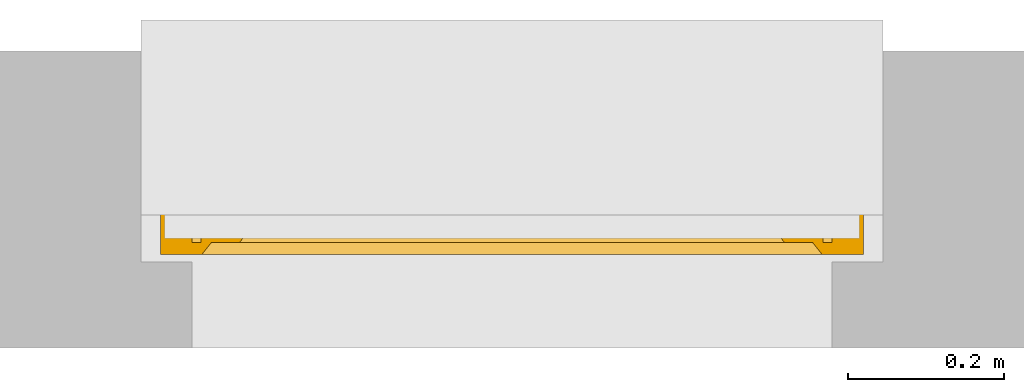
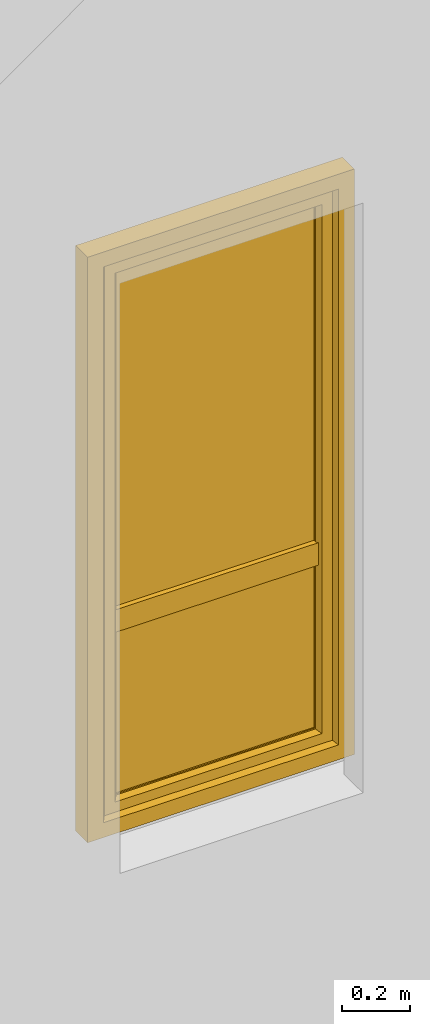
# One storey, part 2 of 3: 1 window.
"""IFC2X3 building model written with IfcOpenShell, lengths in millimetres."""

from ifc_helpers import new_model, entity, si_unit, converted_unit, derived_unit, direction, frame, origin, place, context, subcontext, project, spatial, faceted_brep, source, transform, mapped, material, material_list, type_object, type_shapes, element, save


model = new_model("IFC2X3")

# Units and contexts
model_context = context("Model", 3, precision=0.01, world=origin(), true_north=direction((6.12303176911189e-17, 1.0)))
context_of_model = context(None, 3, precision=0.01, world=origin(), true_north=direction((6.12303176911189e-17, 1.0)))
body_context = subcontext(model_context, "Body", "Model", "MODEL_VIEW")
ifc_project = project(units=[si_unit("LENGTHUNIT", "METRE", prefix="MILLI"), si_unit("AREAUNIT", "SQUARE_METRE"), si_unit("VOLUMEUNIT", "CUBIC_METRE"), converted_unit("PLANEANGLEUNIT", "DEGREE", entity("IfcRatioMeasure", 0.0174532925199433), si_unit("PLANEANGLEUNIT", "RADIAN"), dimensions=[0, 0, 0, 0, 0, 0, 0]), si_unit("MASSUNIT", "GRAM", prefix="KILO"), si_unit("TIMEUNIT", "SECOND"), si_unit("FREQUENCYUNIT", "HERTZ"), si_unit("THERMODYNAMICTEMPERATUREUNIT", "DEGREE_CELSIUS"), derived_unit("THERMALTRANSMITTANCEUNIT", [(si_unit("MASSUNIT", "GRAM", prefix="KILO"), 1), (si_unit("THERMODYNAMICTEMPERATUREUNIT", "KELVIN"), -1), (si_unit("TIMEUNIT", "SECOND"), -3)]), derived_unit("VOLUMETRICFLOWRATEUNIT", [(si_unit("LENGTHUNIT", "METRE"), 3), (si_unit("TIMEUNIT", "SECOND"), -1)]), si_unit("ELECTRICCURRENTUNIT", "AMPERE"), si_unit("ELECTRICVOLTAGEUNIT", "VOLT"), si_unit("POWERUNIT", "WATT"), si_unit("FORCEUNIT", "NEWTON", prefix="KILO"), si_unit("ILLUMINANCEUNIT", "LUX"), si_unit("LUMINOUSFLUXUNIT", "LUMEN"), si_unit("LUMINOUSINTENSITYUNIT", "CANDELA"), si_unit("PRESSUREUNIT", "PASCAL")], contexts=[model_context, context_of_model])

# Site, building, storey
site_placement = place(None, origin())
site = spatial("IfcSite", under=ifc_project, at=site_placement, CompositionType="ELEMENT")
building_placement = place(site_placement, origin())
building = spatial("IfcBuilding", under=site, at=building_placement, CompositionType="ELEMENT")
storey_placement = place(building_placement, origin())
storey = spatial("IfcBuildingStorey", under=building, at=storey_placement, CompositionType="ELEMENT", Elevation=0.0)

# Window
ifc_material_1 = material()
ifc_material_2 = material()
ifc_material_3 = material(Name="Rubber, Black")
ifc_material_4 = material()
ifc_material_5 = material()
ifc_material_list_1 = material_list([ifc_material_1, ifc_material_2, ifc_material_3, ifc_material_4, ifc_material_5])
ifc_material_list_2 = material_list([ifc_material_1, ifc_material_2, ifc_material_3, ifc_material_4, ifc_material_5])
window_style = type_object("IfcWindowStyle", ConstructionType="NOTDEFINED", OperationType="NOTDEFINED", ParameterTakesPrecedence=False, Sizeable=False, material=ifc_material_list_2)
shared_shape = source(origin(), body_context, "Body", "Brep", [
    faceted_brep([(-363.0, -95.0, 1063.0), (-363.0, -95.0, 1027.0), (-363.0, -87.0, 1027.0), (-363.0, -87.0, 1063.0), (-363.843235975199, -87.0, 1067.78534851355), (-363.422218385848, -95.0, 1065.39432433825), (-368.138446626751, -95.0, 1073.56228263264), (-369.997972538787, -87.0, 1075.12318487168), (-370.001013804009, -95.0, 1075.12494091651), (-385.861553373234, -87.0, 1073.56228263264), (-384.002027461198, -95.0, 1075.12318487169), (-383.998986195975, -87.0, 1075.12494091651), (-366.273622272693, -87.0, 1071.99693396951), (-366.275879449492, -95.0, 1071.99962434876), (-365.060158110598, -95.0, 1069.89413651262), (-374.567004156991, -87.0, 1076.78696961731), (-374.570462631182, -95.0, 1076.78757948931), (-372.285738217596, -95.0, 1075.95626020291), (-368.13579740574, -87.0, 1073.5600594206), (-363.844436771704, -95.0, 1067.78864867647), (-365.058429123946, -87.0, 1069.89114124153), (-372.282488347889, -87.0, 1075.9550772445), (-379.429537368803, -87.0, 1076.78757948931), (-379.432995842994, -95.0, 1076.78696961731), (-377.001729237088, -95.0, 1076.78727455331), (-381.717511652096, -95.0, 1075.9550772445), (-381.714261782389, -87.0, 1075.95626020291), (-388.941570876039, -95.0, 1069.89114124153), (-390.155563228281, -87.0, 1067.78864867647), (-390.156764024786, -95.0, 1067.78534851355), (-387.724120550493, -87.0, 1071.99962434876), (-387.726377727292, -95.0, 1071.99693396951), (-385.864202594245, -95.0, 1073.5600594206), (-376.998270762897, -87.0, 1076.78727455331), (-391.0, -95.0, 1063.0), (-390.577781614137, -87.0, 1065.39432433825), (-391.0, -87.0, 1063.0), (-388.939841889387, -87.0, 1069.89413651262), (-391.0, -95.0, 1027.0), (-391.0, -87.0, 1027.0), (-390.156764024786, -95.0, 1022.21465148647), (-390.156764024786, -87.0, 1022.21465148647), (-384.002027461198, -95.0, 1014.87681512833), (-385.864202594245, -95.0, 1016.43994057942), (-387.726377727292, -95.0, 1018.00306603051), (-387.726377727292, -87.0, 1018.00306603051), (-385.864202594245, -87.0, 1016.43994057942), (-384.002027461198, -87.0, 1014.87681512833), (-363.422218385848, -95.0, 1024.60567566177), (-363.844436771704, -95.0, 1022.21135132354), (-363.844436771704, -87.0, 1022.21135132354), (-363.430917360252, -87.0, 1024.55634534639), (-388.941570876039, -87.0, 1020.10885875849), (-388.941570876039, -95.0, 1020.10885875849), (-381.717511652096, -87.0, 1014.04492275552), (-379.432995842994, -87.0, 1013.21303038271), (-379.432995842994, -95.0, 1013.21303038271), (-381.717511652096, -95.0, 1014.04492275552), (-374.570462631182, -95.0, 1013.2124205107), (-377.001729237088, -95.0, 1013.21272544671), (-377.001729237088, -87.0, 1013.21272544671), (-374.570462631182, -87.0, 1013.2124205107), (-372.285738217596, -87.0, 1014.0437397971), (-370.00101380401, -87.0, 1014.8750590835), (-370.00101380401, -95.0, 1014.8750590835), (-372.285738217596, -95.0, 1014.0437397971), (-368.138446626751, -87.0, 1016.43771736738), (-366.275879449492, -87.0, 1018.00037565126), (-366.275879449492, -95.0, 1018.00037565126), (-368.138446626751, -95.0, 1016.43771736738), (-365.060158110598, -87.0, 1020.1058634874), (-365.060158110598, -95.0, 1020.1058634874), (-386.363961030671, -97.0, 1069.3639610307), (-387.242640687112, -97.0, 1067.24264068714), (-388.121320343552, -97.0, 1065.12132034358), (-389.0, -97.0, 1063.0), (-389.0, -97.0, 1027.0), (-388.121320343552, -97.0, 1024.87867965644), (-387.242640687112, -97.0, 1022.75735931288), (-386.363961030672, -97.0, 1020.63603896932), (-385.485281374231, -97.0, 1018.51471862576), (-383.363961030672, -97.0, 1017.63603896932), (-381.242640687112, -97.0, 1016.75735931288), (-379.121320343552, -97.0, 1015.87867965644), (-377.0, -97.0, 1015.0), (-374.878679656433, -97.0, 1015.87867965644), (-372.757359312873, -97.0, 1016.75735931288), (-370.636038969314, -97.0, 1017.63603896932), (-368.514718625754, -97.0, 1018.51471862576), (-367.636038969314, -97.0, 1020.63603896932), (-366.757359312873, -97.0, 1022.75735931288), (-365.878679656433, -97.0, 1024.87867965644), (-365.0, -97.0, 1027.0), (-365.0, -97.0, 1063.0), (-365.878679656433, -97.0, 1065.12132034358), (-366.757359312873, -97.0, 1067.24264068714), (-367.636038969314, -97.0, 1069.3639610307), (-368.514718625754, -97.0, 1071.48528137426), (-370.636038969314, -97.0, 1072.3639610307), (-372.757359312873, -97.0, 1073.24264068714), (-374.878679656433, -97.0, 1074.12132034358), (-377.0, -97.0, 1075.0), (-379.121320343552, -97.0, 1074.12132034358), (-381.242640687112, -97.0, 1073.24264068714), (-383.363961030671, -97.0, 1072.3639610307), (-385.485281374231, -97.0, 1071.48528137426), (-389.0, -85.0, 1063.0), (-388.121320343552, -85.0, 1065.12132034358), (-387.242640687112, -85.0, 1067.24264068714), (-386.363961030672, -85.0, 1069.3639610307), (-385.485281374231, -85.0, 1071.48528137426), (-383.363961030672, -85.0, 1072.3639610307), (-381.242640687112, -85.0, 1073.24264068714), (-379.121320343552, -85.0, 1074.12132034358), (-377.0, -85.0, 1075.0), (-374.878679656433, -85.0, 1074.12132034358), (-372.757359312873, -85.0, 1073.24264068714), (-370.636038969314, -85.0, 1072.3639610307), (-368.514718625754, -85.0, 1071.48528137426), (-367.636038969314, -85.0, 1069.3639610307), (-366.757359312873, -85.0, 1067.24264068714), (-365.878679656433, -85.0, 1065.12132034358), (-365.0, -85.0, 1063.0), (-365.0, -85.0, 1027.0), (-365.878679656433, -85.0, 1024.87867965644), (-366.757359312873, -85.0, 1022.75735931288), (-367.636038969314, -85.0, 1020.63603896932), (-368.514718625754, -85.0, 1018.51471862576), (-370.636038969314, -85.0, 1017.63603896932), (-372.757359312873, -85.0, 1016.75735931288), (-374.878679656433, -85.0, 1015.87867965644), (-377.0, -85.0, 1015.0), (-379.121320343552, -85.0, 1015.87867965644), (-381.242640687112, -85.0, 1016.75735931288), (-383.363961030671, -85.0, 1017.63603896932), (-385.485281374231, -85.0, 1018.51471862576), (-386.363961030671, -85.0, 1020.63603896932), (-387.242640687112, -85.0, 1022.75735931288), (-388.121320343552, -85.0, 1024.87867965644), (-389.0, -85.0, 1027.0)], [[[0, 1, 2, 3]], [[4, 5, 3]], [[6, 7, 8]], [[9, 10, 11]], [[12, 13, 14]], [[15, 16, 17]], [[7, 6, 18]], [[5, 0, 3]], [[18, 6, 13]], [[14, 19, 20]], [[4, 19, 5]], [[15, 17, 21]], [[8, 21, 17]], [[12, 14, 20]], [[22, 23, 24]], [[25, 11, 10]], [[26, 23, 22]], [[27, 28, 29]], [[21, 8, 7]], [[20, 19, 4]], [[30, 31, 32]], [[33, 16, 15]], [[34, 35, 36]], [[11, 25, 26]], [[23, 26, 25]], [[37, 27, 31]], [[32, 10, 9]], [[29, 28, 35]], [[30, 32, 9]], [[34, 29, 35]], [[28, 27, 37]], [[18, 13, 12]], [[33, 24, 16]], [[37, 31, 30]], [[22, 24, 33]], [[38, 34, 36, 39]], [[40, 38, 39, 41]], [[42, 43, 44, 45, 46, 47]], [[2, 1, 48, 49, 50, 51]], [[41, 52, 45, 44, 53, 40]], [[47, 54, 55, 56, 57, 42]], [[58, 59, 56, 55, 60, 61]], [[61, 62, 63, 64, 65, 58]], [[66, 67, 68, 69, 64, 63]], [[67, 70, 50, 49, 71, 68]], [[72, 73, 74, 75, 76, 77, 78, 79, 80, 81, 82, 83, 84, 85, 86, 87, 88, 89, 90, 91, 92, 93, 94, 95, 96, 97, 98, 99, 100, 101, 102, 103, 104, 105]], [[92, 48, 1]], [[48, 92, 91]], [[71, 49, 90]], [[44, 79, 53]], [[90, 49, 91]], [[78, 40, 53]], [[88, 68, 89]], [[88, 69, 68]], [[69, 87, 64]], [[89, 68, 71]], [[82, 57, 83]], [[91, 49, 48]], [[65, 85, 58]], [[82, 42, 57]], [[56, 84, 83]], [[65, 64, 86]], [[56, 83, 57]], [[76, 38, 77]], [[58, 84, 56, 59]], [[80, 44, 43]], [[85, 65, 86]], [[40, 77, 38]], [[82, 81, 42]], [[40, 78, 77]], [[43, 81, 80]], [[71, 90, 89]], [[87, 69, 88]], [[79, 44, 80]], [[79, 78, 53]], [[87, 86, 64]], [[85, 84, 58]], [[43, 42, 81]], [[92, 1, 0, 93]], [[72, 31, 27]], [[34, 74, 29]], [[27, 29, 73]], [[13, 96, 14]], [[74, 73, 29]], [[95, 19, 14]], [[104, 32, 105]], [[105, 32, 31]], [[32, 104, 10]], [[105, 31, 72]], [[99, 17, 100]], [[74, 34, 75]], [[25, 102, 23]], [[99, 8, 17]], [[16, 101, 100]], [[25, 10, 103]], [[16, 100, 17]], [[5, 93, 0]], [[99, 98, 8]], [[97, 13, 6]], [[93, 5, 94]], [[102, 25, 103]], [[94, 5, 19]], [[24, 23, 101, 16]], [[27, 73, 72]], [[96, 13, 97]], [[6, 98, 97]], [[96, 95, 14]], [[104, 103, 10]], [[102, 101, 23]], [[6, 8, 98]], [[94, 19, 95]], [[75, 34, 38, 76]], [[106, 107, 108, 109, 110, 111, 112, 113, 114, 115, 116, 117, 118, 119, 120, 121, 122, 123, 124, 125, 126, 127, 128, 129, 130, 131, 132, 133, 134, 135, 136, 137, 138, 139]], [[136, 45, 52]], [[39, 138, 41]], [[52, 41, 137]], [[67, 126, 70]], [[138, 137, 41]], [[125, 50, 70]], [[134, 46, 135]], [[135, 46, 45]], [[46, 134, 47]], [[135, 45, 136]], [[129, 62, 130]], [[138, 39, 139]], [[54, 132, 55]], [[129, 63, 62]], [[61, 131, 130]], [[54, 47, 133]], [[61, 130, 62]], [[51, 123, 2]], [[129, 128, 63]], [[127, 67, 66]], [[123, 51, 124]], [[132, 54, 133]], [[124, 51, 50]], [[60, 55, 131, 61]], [[52, 137, 136]], [[126, 67, 127]], [[66, 128, 127]], [[126, 125, 70]], [[134, 133, 47]], [[132, 131, 55]], [[66, 63, 128]], [[124, 50, 125]], [[122, 3, 2, 123]], [[119, 12, 20]], [[3, 121, 4]], [[20, 4, 120]], [[30, 109, 37]], [[121, 120, 4]], [[108, 28, 37]], [[117, 18, 118]], [[118, 18, 12]], [[18, 117, 7]], [[118, 12, 119]], [[112, 26, 113]], [[121, 3, 122]], [[21, 115, 15]], [[112, 11, 26]], [[22, 114, 113]], [[21, 7, 116]], [[22, 113, 26]], [[35, 106, 36]], [[112, 111, 11]], [[110, 30, 9]], [[106, 35, 107]], [[115, 21, 116]], [[107, 35, 28]], [[33, 15, 114, 22]], [[20, 120, 119]], [[109, 30, 110]], [[9, 111, 110]], [[109, 108, 37]], [[117, 116, 7]], [[115, 114, 15]], [[9, 11, 111]], [[107, 28, 108]], [[139, 39, 36, 106]]]),
    faceted_brep([(-382.291502622106, -145.276775255392, 985.521147966165), (-371.708497377848, -145.276775255393, 985.521147966165), (-371.708497377848, -140.837885234758, 1027.66882878318), (-382.291502622106, -140.837885234757, 1027.66882878318), (-369.516685226428, -136.448348130647, 985.521147966165), (-369.516685226428, -132.203155672521, 1025.82965209673), (-377.0, -131.276775255392, 985.521147966165), (-377.0, -127.145048202385, 1024.75228733741), (-384.483314773524, -136.448348130645, 985.521147966165), (-384.483314773524, -132.203155672519, 1025.82965209673), (-382.291502622106, -140.837885234758, 943.373467149146), (-371.708497377848, -140.837885234759, 943.373467149146), (-369.516685226428, -132.203155672522, 945.212643835597), (-377.0, -127.145048202386, 946.29000859492), (-384.483314773524, -132.20315567252, 945.212643835597)], [[[0, 1, 2, 3]], [[1, 4, 5, 2]], [[4, 6, 7, 5]], [[6, 8, 9, 7]], [[8, 0, 3, 9]], [[10, 11, 1, 0]], [[11, 12, 4, 1]], [[12, 13, 6, 4]], [[13, 14, 8, 6]], [[14, 10, 0, 8]], [[3, 2, 5, 7, 9]], [[14, 13, 12, 11, 10]]]),
    faceted_brep([(-386.948919316965, -97.0, 1045.94591729901), (-386.388304441297, -97.0, 1048.43924096907), (-385.210737936943, -97.0, 1050.70333478471), (-383.494826146008, -97.0, 1052.59726390535), (-381.358898943517, -97.0, 1054.0), (-377.0, -97.0, 1054.0), (-372.641101056436, -97.0, 1054.0), (-370.505173853945, -97.0, 1052.59726390535), (-368.789262063009, -97.0, 1050.70333478471), (-367.611695558655, -97.0, 1048.43924096907), (-367.051080682988, -97.0, 1045.94591729901), (-367.13090453415, -97.0, 1043.3919203214), (-367.862798628599, -97.0, 1040.94604186494), (-369.190544488104, -97.0, 1038.7614130413), (-371.022965207414, -97.0, 1036.98307257928), (-373.251994222266, -97.0, 1035.73512735946), (-375.723700590377, -97.0, 1035.08403873227), (-378.276299409575, -97.0, 1035.08403873227), (-380.748005777687, -97.0, 1035.73512735946), (-382.977034792538, -97.0, 1036.98307257928), (-384.809455511848, -97.0, 1038.7614130413), (-386.137201371354, -97.0, 1040.94604186494), (-386.869095465803, -97.0, 1043.3919203214), (-383.630084186039, -139.571199871011, 1026.81582813483), (-384.544657376314, -138.066781139833, 1025.80273507336), (-384.969670400813, -136.42046719477, 1024.69408812541), (-384.881729331265, -134.736601923398, 1023.56015367782), (-384.28801801609, -133.126161127661, 1022.47566412563), (-383.220022030302, -131.692818084303, 1021.51043425854), (-381.755121821292, -130.525776486187, 1020.72453488026), (-379.981030164164, -129.706502117789, 1020.17282599704), (-378.015004374953, -129.280982287031, 1019.88627599662), (-375.984995624999, -129.280982287031, 1019.88627599662), (-374.018969835788, -129.706502117789, 1020.17282599704), (-372.24487817866, -130.525776486188, 1020.72453488026), (-370.779977969651, -131.692818084303, 1021.51043425854), (-369.711981983862, -133.126161127661, 1022.47566412563), (-369.118270668688, -134.736601923398, 1023.56015367782), (-369.030329599139, -136.420467194771, 1024.69408812541), (-369.455342623639, -138.066781139833, 1025.80273507336), (-370.369915813914, -139.571199871011, 1026.81582813483), (-371.708497377847, -140.838667192924, 1027.6693553629), (-375.206894448272, -140.838667192924, 1027.6693553629), (-378.749198535189, -140.838667192924, 1027.6693553629), (-382.291502622105, -140.838667192924, 1027.6693553629), (-374.470501119521, -126.416323041036, 1043.53479166182), (-377.0, -123.592503743986, 1045.46960324719), (-376.978047137813, -133.930955778539, 1036.86725150298), (-371.827409391356, -136.56784382523, 1032.7486255059), (-374.246224213147, -134.00299976312, 1036.79007956711), (-379.379075047105, -127.567125778351, 1042.66721198755), (-379.237157342969, -119.178161613072, 1048.00337884315), (-381.980634729243, -129.673589570168, 1040.9479296637), (-379.841946810805, -134.921809886446, 1035.7785343575), (-378.031674795436, -110.940739168215, 1051.41174131507), (-381.66976683638, -114.56747742195, 1050.10298096761), (-374.907940881426, -106.916614530038, 1052.54270145077), (-372.01936527071, -129.673589570169, 1040.9479296637), (-372.330233163573, -114.56747742195, 1050.10298096761), (-368.665547370107, -129.075791149358, 1030.92276589623), (-368.132073829393, -116.519842499669, 1043.07942490614), (-367.540900854048, -107.240572966481, 1045.08550854293), (-373.085967686741, -125.260625550192, 1025.68801313963), (-371.380283644659, -120.444255008272, 1030.78506579306), (-383.974790089265, -123.255273619438, 1030.70424775684), (-386.0177165191, -115.101506888523, 1043.22389640408), (-383.818882821001, -112.022437290068, 1035.92399318818), (-370.15596584972, -109.417405225716, 1036.67364545902), (-368.264592593692, -123.544355953055, 1037.17506192801), (-386.306850420165, -106.118963862196, 1041.84627828438), (-379.52980153325, -104.68468755909, 1034.97313305255)], [[[0, 1, 2, 3, 4, 5, 6, 7, 8, 9, 10, 11, 12, 13, 14, 15, 16, 17, 18, 19, 20, 21, 22]], [[23, 24, 25, 26, 27, 28, 29, 30, 31, 32, 33, 34, 35, 36, 37, 38, 39, 40, 41, 42, 43, 44]], [[45, 46, 47]], [[42, 41, 48]], [[49, 45, 47]], [[50, 46, 51]], [[50, 51, 52]], [[43, 47, 53]], [[53, 50, 52]], [[54, 4, 55]], [[44, 43, 53]], [[56, 6, 5]], [[48, 49, 42]], [[42, 47, 43]], [[49, 48, 57]], [[5, 54, 56]], [[49, 57, 45]], [[42, 49, 47]], [[57, 58, 45]], [[58, 46, 45]], [[50, 47, 46]], [[44, 53, 52]], [[47, 50, 53]], [[46, 54, 51]], [[56, 46, 58]], [[4, 54, 5]], [[54, 55, 51]], [[52, 51, 55]], [[46, 56, 54]], [[6, 56, 58]], [[40, 59, 41]], [[39, 38, 59]], [[59, 40, 39]], [[36, 59, 37]], [[60, 61, 58]], [[35, 34, 62]], [[62, 59, 36]], [[59, 62, 63]], [[33, 62, 34]], [[35, 62, 36]], [[38, 37, 59]], [[9, 8, 61]], [[61, 10, 9]], [[64, 65, 66]], [[8, 7, 61]], [[58, 7, 6]], [[58, 61, 7]], [[63, 67, 68]], [[67, 13, 61]], [[52, 55, 65]], [[67, 60, 68]], [[31, 62, 32]], [[59, 68, 57]], [[13, 67, 14]], [[65, 69, 66]], [[10, 61, 11]], [[11, 61, 12]], [[69, 55, 1]], [[16, 70, 17]], [[33, 32, 62]], [[66, 67, 63]], [[69, 70, 66]], [[67, 66, 70]], [[70, 15, 67]], [[29, 64, 30]], [[27, 64, 28]], [[64, 29, 28]], [[65, 64, 52]], [[25, 24, 64]], [[57, 60, 58]], [[64, 24, 52]], [[23, 44, 52]], [[67, 61, 60]], [[23, 52, 24]], [[64, 26, 25]], [[69, 65, 55]], [[63, 64, 66]], [[69, 20, 19]], [[69, 21, 20]], [[61, 13, 12]], [[60, 57, 68]], [[70, 16, 15]], [[17, 70, 18]], [[68, 59, 63]], [[62, 64, 63]], [[19, 18, 70]], [[69, 1, 0]], [[0, 22, 69]], [[1, 55, 2]], [[30, 62, 31]], [[64, 27, 26]], [[3, 2, 55]], [[4, 3, 55]], [[19, 70, 69]], [[15, 14, 67]], [[21, 69, 22]], [[59, 57, 48, 41]], [[64, 62, 30]]]),
    faceted_brep([(398.0, -15.0, 2038.0), (398.0, -70.0, 2038.0), (398.0, -70.0, 52.0), (398.0, -15.0, 52.0), (337.000081964466, -30.0, 1977.00008196447), (349.0, -15.0, 1989.0), (349.0, -15.0, 101.0), (337.000081964466, -30.0, 112.999918035527), (365.0, -72.0, 2005.0), (365.0, -30.0, 2005.0), (365.0, -30.0, 85.0), (365.0, -72.0, 85.0), (349.0, -84.0, 1989.0), (337.0, -72.0, 1977.0), (337.0, -72.0, 113.0), (349.0, -84.0, 101.0), (362.0, -85.0, 2002.0), (362.0, -84.0, 2002.0), (362.0, -84.0, 88.0), (362.0, -85.0, 88.0), (418.0, -83.0, 2058.0), (416.0, -85.0, 2056.0), (416.0, -85.0, 34.0), (418.0, -83.0, 32.0), (418.0, -70.0, 2058.0), (418.0, -70.0, 32.0), (-398.0, -70.0, 52.0), (-398.0, -15.0, 52.0), (-349.0, -15.0, 101.0), (-337.000081964469, -30.0, 112.999918035527), (-365.0, -30.0, 85.0), (-365.0, -72.0, 85.0), (-337.0, -72.0, 113.0), (-349.0, -84.0, 101.0), (-362.0, -84.0, 88.0), (-362.0, -85.0, 88.0), (-416.0, -85.0, 34.0), (-418.0, -83.0, 32.0), (-418.0, -70.0, 32.0), (-398.0, -70.0, 2038.0), (-398.0, -15.0, 2038.0), (-349.0, -15.0, 1989.0), (-337.00008196447, -30.0, 1977.00008196447), (-365.0, -30.0, 2005.0), (-365.0, -72.0, 2005.0), (-337.0, -72.0, 1977.0), (-349.0, -84.0, 1989.0), (-362.0, -84.0, 2002.0), (-362.0, -85.0, 2002.0), (-416.0, -85.0, 2056.0), (-418.0, -83.0, 2058.0), (-418.0, -70.0, 2058.0)], [[[0, 1, 2, 3]], [[4, 5, 6, 7]], [[8, 9, 10, 11]], [[12, 13, 14, 15]], [[16, 17, 18, 19]], [[20, 21, 22, 23]], [[24, 20, 23, 25]], [[3, 2, 26, 27]], [[7, 6, 28, 29]], [[11, 10, 30, 31]], [[15, 14, 32, 33]], [[19, 18, 34, 35]], [[23, 22, 36, 37]], [[25, 23, 37, 38]], [[27, 26, 39, 40]], [[29, 28, 41, 42]], [[31, 30, 43, 44]], [[33, 32, 45, 46]], [[35, 34, 47, 48]], [[37, 36, 49, 50]], [[38, 37, 50, 51]], [[40, 39, 1, 0]], [[3, 27, 40, 0], [5, 41, 28, 6]], [[42, 41, 5, 4]], [[7, 29, 42, 4], [9, 43, 30, 10]], [[44, 43, 9, 8]], [[11, 31, 44, 8], [13, 45, 32, 14]], [[46, 45, 13, 12]], [[15, 33, 46, 12], [17, 47, 34, 18]], [[48, 47, 17, 16]], [[19, 35, 48, 16], [21, 49, 36, 22]], [[50, 49, 21, 20]], [[51, 50, 20, 24]], [[1, 39, 26, 2], [25, 38, 51, 24]]], outer=[[True], [True], [True], [True], [True], [True], [True], [True], [True], [True], [True], [True], [True], [True], [True], [True], [True], [True], [True], [True], [True], [True], [True, False], [True], [False, True], [True], [True, False], [True], [False, True], [True], [False, True], [True], [True], [False, True]]),
    faceted_brep([(-365.0, -67.0, 85.0), (-365.0, -35.0, 85.0), (365.0, -35.0, 85.0), (365.0, -67.0, 85.0), (-337.0, -62.0, 113.0), (-337.0, -67.0, 113.0), (337.0, -67.0, 113.0), (337.0, -62.0, 113.0), (-353.0, -40.0, 97.0), (-353.0, -62.0, 97.0), (353.0, -62.0, 97.0), (353.0, -40.0, 97.0), (-337.0, -35.0, 113.0), (-337.0, -40.0, 113.0), (337.0, -40.0, 113.0), (337.0, -35.0, 113.0), (365.0, -35.0, 2005.0), (365.0, -67.0, 2005.0), (337.0, -67.0, 1977.0), (337.0, -62.0, 1977.0), (353.0, -62.0, 1993.0), (353.0, -40.0, 1993.0), (337.0, -40.0, 1977.0), (337.0, -35.0, 1977.0), (-365.0, -35.0, 2005.0), (-365.0, -67.0, 2005.0), (-337.0, -67.0, 1977.0), (-337.0, -62.0, 1977.0), (-353.0, -62.0, 1993.0), (-353.0, -40.0, 1993.0), (-337.0, -40.0, 1977.0), (-337.0, -35.0, 1977.0)], [[[0, 1, 2, 3]], [[4, 5, 6, 7]], [[8, 9, 10, 11]], [[12, 13, 14, 15]], [[3, 2, 16, 17]], [[7, 6, 18, 19]], [[11, 10, 20, 21]], [[15, 14, 22, 23]], [[17, 16, 24, 25]], [[19, 18, 26, 27]], [[21, 20, 28, 29]], [[23, 22, 30, 31]], [[15, 23, 31, 12], [1, 24, 16, 2]], [[25, 24, 1, 0]], [[3, 17, 25, 0], [5, 26, 18, 6]], [[27, 26, 5, 4]], [[7, 19, 27, 4], [9, 28, 20, 10]], [[29, 28, 9, 8]], [[11, 21, 29, 8], [13, 30, 22, 14]], [[31, 30, 13, 12]]], outer=[[True], [True], [True], [True], [True], [True], [True], [True], [True], [True], [True], [True], [False, True], [True], [True, False], [True], [False, True], [True], [True, False], [True]]),
    faceted_brep([(345.0, -65.0, 105.0), (345.0, -65.0, 700.0), (-345.0, -65.0, 700.0), (-345.0, -65.0, 105.0), (345.0, -43.0, 105.0), (-345.0, -43.0, 105.0), (-345.0, -43.0, 700.0), (345.0, -43.0, 700.0)], [[[0, 1, 2, 3]], [[4, 5, 6, 7]], [[1, 0, 4, 7]], [[2, 1, 7, 6]], [[3, 2, 6, 5]], [[0, 3, 5, 4]]]),
    faceted_brep([(-345.0, -62.0, 1989.0), (-345.0, -62.0, 760.0), (349.0, -62.0, 760.0), (349.0, -62.0, 1989.0), (-345.0, -40.0, 1989.0), (349.0, -40.0, 1989.0), (349.0, -40.0, 760.0), (-345.0, -40.0, 760.0)], [[[0, 1, 2, 3]], [[4, 5, 6, 7]], [[1, 0, 4, 7]], [[2, 1, 7, 6]], [[3, 2, 6, 5]], [[0, 3, 5, 4]]]),
    faceted_brep([(345.0, -23.0, 700.0), (345.0, -23.0, 780.0), (345.0, -85.0, 780.0), (345.0, -85.0, 700.0), (-345.0, -23.0, 780.0), (-345.0, -23.0, 700.0), (-345.0, -85.0, 700.0), (-345.0, -85.0, 780.0)], [[[0, 1, 2, 3]], [[4, 5, 6, 7]], [[2, 1, 4, 7]], [[2, 7, 6, 3]], [[0, 3, 6, 5]], [[0, 5, 4, 1]]]),
    faceted_brep([(-450.0, -70.0, 2090.0), (-450.0, 0.0, 2090.0), (-450.0, 0.0, 0.0), (-450.0, -70.0, 0.0), (-410.0, -15.0, 2050.0), (-410.0, -70.0, 2050.0), (-410.0, -70.0, 40.0), (-410.0, -15.0, 40.0), (-397.0, 0.0, 2037.0), (-385.0, -15.0, 2025.0), (-385.0, -15.0, 65.0), (-397.0, 0.0, 53.0), (450.0, 0.0, 0.0), (450.0, -70.0, 0.0), (410.0, -70.0, 40.0), (410.0, -15.0, 40.0), (385.0, -15.0, 65.0), (397.0, 0.0, 53.0), (450.0, 0.0, 2090.0), (450.0, -70.0, 2090.0), (410.0, -70.0, 2050.0), (410.0, -15.0, 2050.0), (385.0, -15.0, 2025.0), (397.0, 0.0, 2037.0)], [[[0, 1, 2, 3]], [[4, 5, 6, 7]], [[8, 9, 10, 11]], [[3, 2, 12, 13]], [[7, 6, 14, 15]], [[11, 10, 16, 17]], [[13, 12, 18, 19]], [[15, 14, 20, 21]], [[17, 16, 22, 23]], [[11, 17, 23, 8], [1, 18, 12, 2]], [[19, 18, 1, 0]], [[3, 13, 19, 0], [5, 20, 14, 6]], [[21, 20, 5, 4]], [[7, 15, 21, 4], [9, 22, 16, 10]], [[23, 22, 9, 8]]], outer=[[True], [True], [True], [True], [True], [True], [True], [True], [True], [False, True], [True], [True, False], [True], [True, False], [True]]),
])
type_shapes(window_style, [shared_shape])
window_placement = place(storey_placement, frame((-15343.0395459674, 12473.5585138251, 850.0), z_axis=(0.0, 0.0, 1.0), x_axis=(-1.0, 0.0, 0.0)))
element("IfcWindow", 1, at=window_placement, inside=storey, type_object=window_style, material=ifc_material_list_1, OverallHeight=2090.0, OverallWidth=950.000000000005, context=body_context, shape_type="MappedRepresentation", body=[
    mapped(shared_shape, transform((0.0, 0.0, 0.0), scale=1.0)),
])

save(model, "model.ifc")
